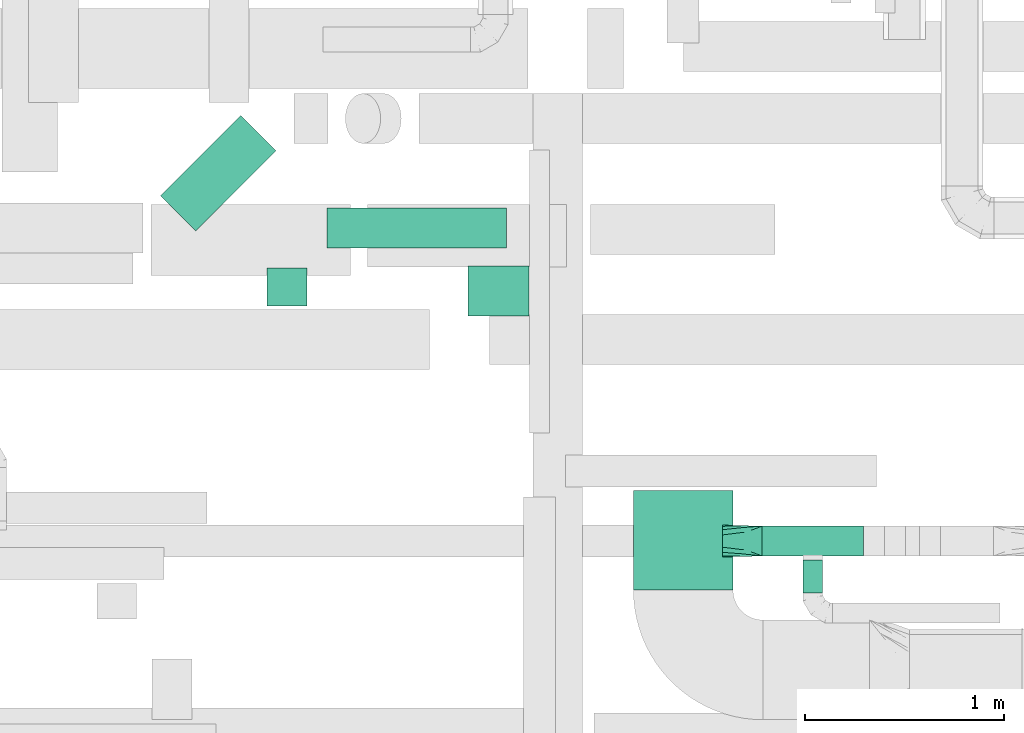
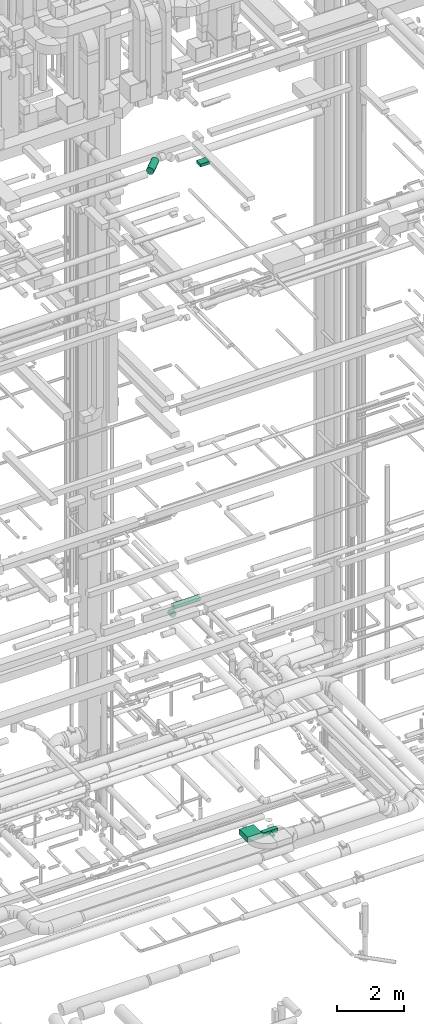
# One storey, part 209 of 337: 7 flow segments, 1 flow fitting.
"""IFC2X3 building model written with IfcOpenShell, lengths in millimetres."""

import ifcopenshell
import ifcopenshell.guid

model = None  # the IFC model being written
_history = None  # IfcOwnerHistory: only IFC2X3 demands one
_inside = {}  # id of a spatial element -> (the spatial element, [elements in it])
_under = {}  # id of a project, library or spatial element -> (it, [spatial elements below it])
_declared = {}  # id of a project -> (the project, [libraries it declares])
_typed = {}  # id of a type object -> (the type object, [elements of that type])
_made_of = {}  # id of a material, layer set ... -> (it, [elements and type objects made of it])


def new_model(schema):
    """Start an empty IFC model of exactly this schema.

    Asked for "IFC4X3", IfcOpenShell would pick the latest addendum, in which some entities
    have other attributes; the version numbers below select the first issue.
    IFC2X3 requires an IfcOwnerHistory on every rooted entity: one is made here for all.
    """
    global model, _history
    if schema == "IFC4X3":
        model = ifcopenshell.file(schema_version=(4, 3, 0, 0))
    else:
        model = ifcopenshell.file(schema=schema)
    _inside.clear()
    _under.clear()
    _declared.clear()
    _typed.clear()
    _made_of.clear()
    _history = None
    if model.schema == "IFC2X3":
        org = make("IfcOrganization", Name="unknown")
        user = make(
            "IfcPersonAndOrganization",
            ThePerson=make("IfcPerson", FamilyName="unknown"),
            TheOrganization=org,
        )
        app = make(
            "IfcApplication",
            ApplicationDeveloper=org,
            Version="unknown",
            ApplicationFullName="unknown",
            ApplicationIdentifier="unknown",
        )
        _history = make(
            "IfcOwnerHistory",
            OwningUser=user,
            OwningApplication=app,
            ChangeAction="ADDED",
            CreationDate=0,
        )
    return model


def make(cls, **values):
    """One entity of the class cls with the attributes given. An attribute that is None is left unset."""
    return model.create_entity(
        cls, **{name: value for name, value in values.items() if value is not None}
    )


def entity(cls, *values):
    """Any entity or typed value of the class cls, its attributes in the order of the schema. None: left unset."""
    e = model.create_entity(cls)
    for i, value in enumerate(values):
        if value is not None:
            e[i] = value
    return e


def rooted(cls, **values):
    """An entity with a GlobalId (a new one), such as an element, a storey or a relation."""
    return make(cls, GlobalId=ifcopenshell.guid.new(), OwnerHistory=_history, **values)


def si_unit(unit_type, name, prefix=None):
    """IfcSIUnit, for example si_unit("LENGTHUNIT", "METRE", prefix="MILLI")."""
    return make("IfcSIUnit", UnitType=unit_type, Prefix=prefix, Name=name)


def converted_unit(unit_type, name, factor, base, dimensions=None, offset=None):
    """IfcConversionBasedUnit, such as the inch: factor (a typed value) times the base unit."""
    return make(
        "IfcConversionBasedUnit"
        if offset is None
        else "IfcConversionBasedUnitWithOffset",
        ConversionOffset=offset,
        Dimensions=None
        if dimensions is None
        else entity("IfcDimensionalExponents", *dimensions),
        UnitType=unit_type,
        Name=name,
        ConversionFactor=make(
            "IfcMeasureWithUnit", ValueComponent=factor, UnitComponent=base
        ),
    )


def derived_unit(unit_type, elements):
    """IfcDerivedUnit: a product of units, each with its exponent."""
    return make(
        "IfcDerivedUnit",
        Elements=[
            make("IfcDerivedUnitElement", Unit=unit, Exponent=power)
            for unit, power in elements
        ],
        UnitType=unit_type,
    )


def assignment(units):
    """IfcUnitAssignment: the units of a project."""
    return None if units is None else make("IfcUnitAssignment", Units=units)


def point(xyz):
    """IfcCartesianPoint."""
    return None if xyz is None else make("IfcCartesianPoint", Coordinates=xyz)


def direction(xyz):
    """IfcDirection."""
    return None if xyz is None else make("IfcDirection", DirectionRatios=xyz)


def frame(location, z_axis=None, x_axis=None):
    """IfcAxis2Placement3D, a coordinate frame: its origin and axes. An axis left out is left unset."""
    return make(
        "IfcAxis2Placement3D",
        Location=point(location),
        Axis=direction(z_axis),
        RefDirection=direction(x_axis),
    )


def frame_2d(location, x_axis=None):
    """IfcAxis2Placement2D, a coordinate frame in the plane: its origin and x axis."""
    return make(
        "IfcAxis2Placement2D", Location=point(location), RefDirection=direction(x_axis)
    )


def origin():
    """The frame at (0, 0, 0) with its axes left unset."""
    return frame((0.0, 0.0, 0.0))


def origin_2d_with_axis():
    """The frame at (0, 0) in the plane with the x axis (1, 0) written out."""
    return frame_2d((0.0, 0.0), x_axis=(1.0, 0.0))


def place(relative_to, where):
    """IfcLocalPlacement: puts the frame where relative to a parent placement (None: the world)."""
    return make(
        "IfcLocalPlacement", PlacementRelTo=relative_to, RelativePlacement=where
    )


def context(
    kind, dimensions, precision=None, world=None, true_north=None, identifier=None
):
    """IfcGeometricRepresentationContext, for example the 3D "Model" context."""
    return make(
        "IfcGeometricRepresentationContext",
        ContextIdentifier=identifier,
        ContextType=kind,
        CoordinateSpaceDimension=dimensions,
        Precision=precision,
        WorldCoordinateSystem=world,
        TrueNorth=true_north,
    )


def subcontext(parent, identifier, kind, view, scale=None):
    """IfcGeometricRepresentationSubContext, for example "Body" below "Model"."""
    return make(
        "IfcGeometricRepresentationSubContext",
        ContextIdentifier=identifier,
        ContextType=kind,
        ParentContext=parent,
        TargetScale=scale,
        TargetView=view,
    )


def project(units=None, contexts=None):
    """IfcProject with its units and contexts."""
    return rooted(
        "IfcProject",
        Name="project",
        RepresentationContexts=contexts,
        UnitsInContext=assignment(units),
    )


def spatial(cls, under=None, at=None, **own):
    """A site, building, storey or space (cls), placed at a placement, below another one or the project."""
    s = rooted(cls, ObjectPlacement=at, **own)
    if under is not None:
        _under.setdefault(under.id(), (under, []))[1].append(s)
    return s


def profile(cls, at=None, kind="AREA", **sizes):
    """A parametric profile (cls). Its sizes go by their IFC names, for example OverallWidth=200.0."""
    return make(cls, ProfileType=kind, Position=at, **sizes)


def rectangle(**sizes):
    """IfcRectangleProfileDef."""
    return profile("IfcRectangleProfileDef", **sizes)


def circle(**sizes):
    """IfcCircleProfileDef."""
    return profile("IfcCircleProfileDef", **sizes)


def extrude(swept, where, along, depth):
    """IfcExtrudedAreaSolid: the profile swept, set in the frame where, extruded along a direction by depth."""
    return make(
        "IfcExtrudedAreaSolid",
        SweptArea=swept,
        Position=where,
        ExtrudedDirection=direction(along),
        Depth=depth,
    )


def faces_of(points, faces, orient=None, outer=None):
    """IfcFace entities. A face is a list of loops; a loop is a list of indices into points, from 0.

    orient and outer hold one flag for each loop. By default every Orientation is true, the
    first loop of a face is its IfcFaceOuterBound and the others are IfcFaceBound.
    """
    made = []
    for i, loops in enumerate(faces):
        bounds = []
        for j, loop in enumerate(loops):
            is_outer = j == 0 if outer is None else outer[i][j]
            bounds.append(
                make(
                    "IfcFaceOuterBound" if is_outer else "IfcFaceBound",
                    Bound=make("IfcPolyLoop", Polygon=[points[k] for k in loop]),
                    Orientation=True if orient is None else orient[i][j],
                )
            )
        made.append(make("IfcFace", Bounds=bounds))
    return made


def faceted_brep(points, faces, orient=None, outer=None, voids=None):
    """IfcFacetedBrep: a solid bounded by flat faces; with voids (closed shells), ...WithVoids."""
    shared = [point(p) for p in points]
    hull = make("IfcClosedShell", CfsFaces=faces_of(shared, faces, orient, outer))
    if voids is None:
        return make("IfcFacetedBrep", Outer=hull)
    return make(
        "IfcFacetedBrepWithVoids",
        Outer=hull,
        Voids=[
            make(cls, CfsFaces=faces_of(shared, fs, o, b)) for cls, fs, o, b in voids
        ],
    )


def shape(context_of_items, identifier, shape_type, items):
    """IfcShapeRepresentation: the items that make up one representation, for example the "Body"."""
    return make(
        "IfcShapeRepresentation",
        ContextOfItems=context_of_items,
        RepresentationIdentifier=identifier,
        RepresentationType=shape_type,
        Items=items,
    )


def source(mapping_origin, context_of_items, identifier, shape_type, items):
    """IfcRepresentationMap: a shape defined once, which mapped items show again and again."""
    return make(
        "IfcRepresentationMap",
        MappingOrigin=mapping_origin,
        MappedRepresentation=shape(context_of_items, identifier, shape_type, items),
    )


def transform(
    local_origin,
    x_axis=None,
    y_axis=None,
    z_axis=None,
    scale=None,
    scale2=None,
    scale3=None,
    uniform=True,
):
    """IfcCartesianTransformationOperator3D, or its non-uniform kind. x_axis, y_axis, z_axis: its Axis1, 2, 3."""
    if uniform:
        return make(
            "IfcCartesianTransformationOperator3D",
            Axis1=direction(x_axis),
            Axis2=direction(y_axis),
            LocalOrigin=point(local_origin),
            Scale=scale,
            Axis3=direction(z_axis),
        )
    return make(
        "IfcCartesianTransformationOperator3DnonUniform",
        Axis1=direction(x_axis),
        Axis2=direction(y_axis),
        LocalOrigin=point(local_origin),
        Scale=scale,
        Axis3=direction(z_axis),
        Scale2=scale2,
        Scale3=scale3,
    )


def mapped(mapping_source, mapping_target):
    """IfcMappedItem: shows the shape of a source again, moved by a transform."""
    return make(
        "IfcMappedItem", MappingSource=mapping_source, MappingTarget=mapping_target
    )


def material(Name=None, Category=None):
    """IfcMaterial."""
    return make("IfcMaterial", Name=Name, Category=Category)


def made_of(thing, what):
    """Note that an element or type object is made of a material, layer set ...; save() writes the relation."""
    if what is not None:
        _made_of.setdefault(what.id(), (what, []))[1].append(thing)
    return thing


def type_object(cls, material=None, **own):
    """A type object (cls), such as IfcWallType, which elements share."""
    return made_of(rooted(cls, **own), material)


def type_shapes(of_type, sources):
    """Give a type object the sources (RepresentationMaps) that its elements show as mapped items."""
    of_type.RepresentationMaps = sources


def element(
    cls,
    number,
    at=None,
    inside=None,
    cuts=None,
    type_object=None,
    material=None,
    context=None,
    identifier="Body",
    shape_type=None,
    held_by="IfcProductDefinitionShape",
    body=None,
    shapes=None,
    **own,
):
    """One element of the class cls, such as IfcWall. Its Tag is "e" and its number.

    at: its placement. inside: the storey or other place that contains it. cuts: it is an
    opening in that element (IfcRelVoidsElement). A single representation is given by context,
    identifier, shape_type and body (its items); several are given by shapes. held_by: the class
    of the entity that holds the representations. save() writes the other relations.
    """
    e = rooted(cls, Tag="e%d" % number, ObjectPlacement=at, **own)
    if body is not None:
        shapes = [shape(context, identifier, shape_type, body)]
    if shapes is not None:
        e.Representation = make(held_by, Representations=shapes)
    if inside is not None:
        _inside.setdefault(inside.id(), (inside, []))[1].append(e)
    if cuts is not None:
        rooted(
            "IfcRelVoidsElement", RelatingBuildingElement=cuts, RelatedOpeningElement=e
        )
    if type_object is not None:
        _typed.setdefault(type_object.id(), (type_object, []))[1].append(e)
    return made_of(e, material)


def aggregate(whole, parts):
    """IfcRelAggregates: a whole, such as a stair, and the parts it consists of."""
    return rooted("IfcRelAggregates", RelatingObject=whole, RelatedObjects=parts)


def save(model, path):
    """Write the relations noted so far, then the file.

    IfcRelAggregates (storeys below a building ...), IfcRelContainedInSpatialStructure (elements
    in a storey), IfcRelDefinesByType, IfcRelAssociatesMaterial and IfcRelDeclares: one each for
    every whole, place, type object, material and project.
    """
    for whole, parts in _under.values():
        aggregate(whole, parts)
    for where, things in _inside.values():
        rooted(
            "IfcRelContainedInSpatialStructure",
            RelatedElements=things,
            RelatingStructure=where,
        )
    for kind, things in _typed.values():
        rooted("IfcRelDefinesByType", RelatedObjects=things, RelatingType=kind)
    for what, things in _made_of.values():
        rooted("IfcRelAssociatesMaterial", RelatedObjects=things, RelatingMaterial=what)
    for by, libraries in _declared.values():
        rooted("IfcRelDeclares", RelatingContext=by, RelatedDefinitions=libraries)
    model.write(path)


model = new_model("IFC2X3")

# Units and contexts
model_context = context("Model", 3, precision=0.01, world=origin(), true_north=direction((6.12303176911189e-17, 1.0)))
body_context = subcontext(model_context, "Body", "Model", "MODEL_VIEW")
ifc_project = project(units=[si_unit("LENGTHUNIT", "METRE", prefix="MILLI"), si_unit("AREAUNIT", "SQUARE_METRE"), si_unit("VOLUMEUNIT", "CUBIC_METRE"), converted_unit("PLANEANGLEUNIT", "DEGREE", entity("IfcRatioMeasure", 0.0174532925199433), si_unit("PLANEANGLEUNIT", "RADIAN"), dimensions=[0, 0, 0, 0, 0, 0, 0]), si_unit("MASSUNIT", "GRAM", prefix="KILO"), derived_unit("MASSDENSITYUNIT", [(si_unit("MASSUNIT", "GRAM", prefix="KILO"), 1), (si_unit("LENGTHUNIT", "METRE"), -3)]), derived_unit("MOMENTOFINERTIAUNIT", [(si_unit("LENGTHUNIT", "METRE"), 4)]), si_unit("TIMEUNIT", "SECOND"), si_unit("FREQUENCYUNIT", "HERTZ"), si_unit("THERMODYNAMICTEMPERATUREUNIT", "DEGREE_CELSIUS"), derived_unit("THERMALTRANSMITTANCEUNIT", [(si_unit("MASSUNIT", "GRAM", prefix="KILO"), 1), (si_unit("THERMODYNAMICTEMPERATUREUNIT", "KELVIN"), -1), (si_unit("TIMEUNIT", "SECOND"), -3)]), derived_unit("VOLUMETRICFLOWRATEUNIT", [(si_unit("LENGTHUNIT", "METRE"), 3), (si_unit("TIMEUNIT", "SECOND"), -1)]), derived_unit("MASSFLOWRATEUNIT", [(si_unit("MASSUNIT", "GRAM", prefix="KILO"), 1), (si_unit("TIMEUNIT", "SECOND"), -1)]), derived_unit("ROTATIONALFREQUENCYUNIT", [(si_unit("TIMEUNIT", "SECOND"), -1)]), si_unit("ELECTRICCURRENTUNIT", "AMPERE"), si_unit("ELECTRICVOLTAGEUNIT", "VOLT"), si_unit("POWERUNIT", "WATT"), si_unit("FORCEUNIT", "NEWTON", prefix="KILO"), si_unit("ILLUMINANCEUNIT", "LUX"), si_unit("LUMINOUSFLUXUNIT", "LUMEN"), si_unit("LUMINOUSINTENSITYUNIT", "CANDELA"), derived_unit("USERDEFINED", [(si_unit("MASSUNIT", "GRAM", prefix="KILO"), -1), (si_unit("LENGTHUNIT", "METRE"), -2), (si_unit("TIMEUNIT", "SECOND"), 3), (si_unit("LUMINOUSFLUXUNIT", "LUMEN"), 1)]), derived_unit("LINEARVELOCITYUNIT", [(si_unit("LENGTHUNIT", "METRE"), 1), (si_unit("TIMEUNIT", "SECOND"), -1)]), si_unit("PRESSUREUNIT", "PASCAL"), derived_unit("USERDEFINED", [(si_unit("LENGTHUNIT", "METRE"), -2), (si_unit("MASSUNIT", "GRAM", prefix="KILO"), 1), (si_unit("TIMEUNIT", "SECOND"), -2)]), derived_unit("LINEARFORCEUNIT", [(si_unit("MASSUNIT", "GRAM", prefix="KILO"), 1), (si_unit("LENGTHUNIT", "METRE"), 1), (si_unit("TIMEUNIT", "SECOND"), -2), (si_unit("LENGTHUNIT", "METRE"), -1)]), derived_unit("PLANARFORCEUNIT", [(si_unit("MASSUNIT", "GRAM", prefix="KILO"), 1), (si_unit("LENGTHUNIT", "METRE"), 1), (si_unit("TIMEUNIT", "SECOND"), -2), (si_unit("LENGTHUNIT", "METRE"), -2)])], contexts=[model_context])

# Site, building, storey
site_placement = place(None, origin())
site = spatial("IfcSite", under=ifc_project, at=site_placement, CompositionType="ELEMENT")
building_placement = place(site_placement, origin())
building = spatial("IfcBuilding", under=site, at=building_placement, CompositionType="ELEMENT")
storey_placement = place(building_placement, origin())
storey = spatial("IfcBuildingStorey", under=building, at=storey_placement, CompositionType="ELEMENT", Elevation=0.0)

# Flow segments
duct_segment_type_1 = type_object("IfcDuctSegmentType", PredefinedType="NOTDEFINED")
flow_segment_1_placement = place(storey_placement, frame((59249.3, 5238.77, 27500.0)))
element("IfcFlowSegment", 1, at=flow_segment_1_placement, inside=storey, type_object=duct_segment_type_1, context=body_context, shape_type="SweptSolid", body=[
    extrude(rectangle(XDim=305.269119345866, YDim=249.999999999999, at=origin_2d_with_axis()), frame((152.63, 125.0, 0.0), z_axis=(0.0, 0.0, 1.0), x_axis=(-1.0, 0.0, 0.0)), (0.0, 0.0, 1.0), 100.000000000003),
])
flow_segment_2_placement = place(storey_placement, frame((60078.78, 3864.15, 3300.0)))
element("IfcFlowSegment", 2, at=flow_segment_2_placement, inside=storey, type_object=duct_segment_type_1, context=body_context, shape_type="SweptSolid", body=[
    extrude(rectangle(XDim=500.000000000007, YDim=499.999999999999, at=origin_2d_with_axis()), frame((250.0, 250.0, 0.0), z_axis=(0.0, 0.0, 1.0), x_axis=(0.0, 1.0, 0.0)), (0.0, 0.0, 1.0), 200.0),
])
flow_segment_3_placement = place(storey_placement, frame((60725.0, 4035.29, 3175.0)))
element("IfcFlowSegment", 3, at=flow_segment_3_placement, inside=storey, type_object=duct_segment_type_1, context=body_context, shape_type="SweptSolid", body=[
    extrude(rectangle(XDim=507.883896932124, YDim=150.0, at=origin_2d_with_axis()), frame((253.94, 75.0, 0.0), z_axis=(0.0, 0.0, 1.0), x_axis=(-1.0, 0.0, 0.0)), (0.0, 0.0, 1.0), 150.000000000001),
])
duct_segment_type_2 = type_object("IfcDuctSegmentType", PredefinedType="NOTDEFINED")
flow_segment_4_placement = place(storey_placement, frame((58240.01, 5290.54, 11298.4)))
element("IfcFlowSegment", 4, at=flow_segment_4_placement, inside=storey, type_object=duct_segment_type_2, context=body_context, shape_type="SweptSolid", body=[
    extrude(circle(Radius=100.0, at=origin_2d_with_axis()), frame((101.6, 0.0, 101.6), z_axis=(0.0, 1.0, 0.0), x_axis=(-1.0, 0.0, 0.0)), (0.0, 0.0, 1.0), 190.000000000098),
])
flow_segment_5_placement = place(storey_placement, frame((58541.61, 5578.95, 11298.4)))
element("IfcFlowSegment", 5, at=flow_segment_5_placement, inside=storey, type_object=duct_segment_type_2, context=body_context, shape_type="SweptSolid", body=[
    extrude(circle(Radius=100.0, at=origin_2d_with_axis()), frame((0.0, 101.6, 101.6), z_axis=(1.0, 0.0, 0.0), x_axis=(0.0, -1.0, 0.0)), (0.0, 0.0, 1.0), 899.999999999969),
])
flow_segment_6_placement = place(storey_placement, frame((57705.63, 5663.52, 27423.4)))
element("IfcFlowSegment", 6, at=flow_segment_6_placement, inside=storey, type_object=duct_segment_type_2, context=body_context, shape_type="SweptSolid", body=[
    extrude(circle(Radius=125.0, at=origin_2d_with_axis()), frame((89.98, 89.98, 126.6), z_axis=(0.707106781186518, 0.707106781186577, 0.0), x_axis=(0.707106781186577, -0.707106781186518, 0.0)), (0.0, 0.0, 1.0), 570.112127880552),
])
flow_segment_7_placement = place(storey_placement, frame((60927.15, 3850.29, 3198.4)))
element("IfcFlowSegment", 7, at=flow_segment_7_placement, inside=storey, type_object=duct_segment_type_2, context=body_context, shape_type="SweptSolid", body=[
    extrude(circle(Radius=50.0, at=origin_2d_with_axis()), frame((51.6, 0.0, 51.6), z_axis=(0.0, 1.0, 0.0), x_axis=(1.0, 0.0, 0.0)), (0.0, 0.0, 1.0), 164.999999999989),
])

# Flow fitting
ifc_material = material()
duct_fitting_type = type_object("IfcDuctFittingType", PredefinedType="NOTDEFINED", material=ifc_material)
shared_shape = source(origin(), body_context, "Body", "Brep", [
    faceted_brep([(200.0, 30.61, 73.91), (200.0, 22.87, 75.45), (200.0, 15.12, 76.99), (200.0, 11.34, 77.74), (200.0, 7.56, 78.5), (200.0, 0.0, 80.0), (200.0, -7.56, 78.5), (200.0, -15.12, 76.99), (200.0, -18.99, 76.22), (200.0, -22.87, 75.45), (200.0, -30.61, 73.91), (200.0, -37.1, 69.57), (200.0, -43.59, 65.24), (200.0, -50.08, 60.9), (200.0, -56.57, 56.57), (200.0, -60.9, 50.08), (200.0, -65.24, 43.59), (200.0, -69.57, 37.1), (200.0, -73.91, 30.61), (200.0, -75.45, 22.87), (200.0, -76.99, 15.12), (200.0, -77.74, 11.34), (200.0, -78.5, 7.56), (200.0, -80.0, 0.0), (200.0, -78.5, -7.56), (200.0, -76.99, -15.12), (200.0, -76.22, -18.99), (200.0, -75.45, -22.87), (200.0, -73.91, -30.61), (200.0, -69.57, -37.1), (200.0, -65.24, -43.59), (200.0, -60.9, -50.08), (200.0, -56.57, -56.57), (200.0, -50.08, -60.9), (200.0, -43.59, -65.24), (200.0, -37.1, -69.57), (200.0, -30.61, -73.91), (200.0, -22.87, -75.45), (200.0, -15.12, -76.99), (200.0, -11.34, -77.74), (200.0, -7.56, -78.5), (200.0, 0.0, -80.0), (200.0, 7.56, -78.5), (200.0, 15.12, -76.99), (200.0, 18.99, -76.22), (200.0, 22.87, -75.45), (200.0, 30.61, -73.91), (200.0, 37.1, -69.57), (200.0, 43.59, -65.24), (200.0, 50.08, -60.9), (200.0, 56.57, -56.57), (200.0, 60.9, -50.08), (200.0, 65.24, -43.59), (200.0, 69.57, -37.1), (200.0, 73.91, -30.61), (200.0, 75.45, -22.87), (200.0, 76.99, -15.12), (200.0, 77.74, -11.34), (200.0, 78.5, -7.56), (200.0, 80.0, 0.0), (200.0, 78.5, 7.56), (200.0, 76.99, 15.12), (200.0, 76.22, 18.99), (200.0, 75.45, 22.87), (200.0, 73.91, 30.61), (200.0, 69.57, 37.1), (200.0, 65.24, 43.59), (200.0, 60.9, 50.08), (200.0, 56.57, 56.57), (200.0, 50.08, 60.9), (200.0, 43.59, 65.24), (200.0, 37.1, 69.57), (0.0, -75.0, 75.0), (0.0, 75.0, 75.0), (0.0, 75.0, -75.0), (0.0, -75.0, -75.0), (52.06, -55.48, 76.3), (78.09, -45.72, 76.95), (176.03, -8.99, 79.4), (152.06, -17.98, 78.8), (128.09, -26.97, 78.2), (104.11, -35.96, 77.6), (100.0, -67.44, 64.02), (78.09, -76.95, 45.72), (104.11, -77.6, 35.96), (128.09, -78.2, 26.97), (152.06, -78.8, 17.98), (164.04, -79.1, 13.48), (176.03, -79.4, 8.99), (26.03, -75.65, 65.24), (52.06, -76.3, 55.48), (26.03, -65.24, 75.65), (26.03, -75.65, -65.24), (52.06, -76.3, -55.48), (78.09, -76.95, -45.72), (104.11, -77.6, -35.96), (128.09, -78.2, -26.97), (152.06, -78.8, -17.98), (176.03, -79.4, -8.99), (100.0, -64.02, -67.44), (78.09, -45.72, -76.95), (104.11, -35.96, -77.6), (128.09, -26.97, -78.2), (152.06, -17.98, -78.8), (164.04, -13.48, -79.1), (176.03, -8.99, -79.4), (26.03, -65.24, -75.65), (52.06, -55.48, -76.3), (26.03, 65.24, -75.65), (52.06, 55.48, -76.3), (78.09, 45.72, -76.95), (104.11, 35.96, -77.6), (128.09, 26.97, -78.2), (152.06, 17.98, -78.8), (176.03, 8.99, -79.4), (100.0, 67.44, -64.02), (78.09, 76.95, -45.72), (104.11, 77.6, -35.96), (128.09, 78.2, -26.97), (152.06, 78.8, -17.98), (164.04, 79.1, -13.48), (176.03, 79.4, -8.99), (26.03, 75.65, -65.24), (52.06, 76.3, -55.48), (26.03, 75.65, 65.24), (52.06, 76.3, 55.48), (78.09, 76.95, 45.72), (104.11, 77.6, 35.96), (128.09, 78.2, 26.97), (152.06, 78.8, 17.98), (176.03, 79.4, 8.99), (100.0, 64.02, 67.44), (78.09, 45.72, 76.95), (104.11, 35.96, 77.6), (128.09, 26.97, 78.2), (152.06, 17.98, 78.8), (164.04, 13.48, 79.1), (176.03, 8.99, 79.4), (26.03, 65.24, 75.65), (52.06, 55.48, 76.3)], [[[0, 1, 2, 3, 4, 5, 6, 7, 8, 9, 10, 11, 12, 13, 14, 15, 16, 17, 18, 19, 20, 21, 22, 23, 24, 25, 26, 27, 28, 29, 30, 31, 32, 33, 34, 35, 36, 37, 38, 39, 40, 41, 42, 43, 44, 45, 46, 47, 48, 49, 50, 51, 52, 53, 54, 55, 56, 57, 58, 59, 60, 61, 62, 63, 64, 65, 66, 67, 68, 69, 70, 71]], [[72, 73, 74, 75]], [[76, 12, 77]], [[12, 11, 10, 77]], [[78, 79, 80, 81, 77, 10, 9, 8, 7, 6, 5]], [[13, 82, 14]], [[20, 19, 18, 83, 84, 85, 86, 87, 88, 23, 22, 21]], [[82, 72, 89]], [[82, 15, 14]], [[83, 16, 90]], [[91, 72, 82]], [[18, 17, 16, 83]], [[90, 16, 15]], [[15, 82, 89]], [[90, 15, 89]], [[76, 13, 12]], [[13, 76, 91]], [[82, 13, 91]], [[88, 87, 86, 85, 84, 83, 90, 89, 72, 75, 92, 93, 94, 95, 96, 97, 98, 23]], [[93, 30, 94]], [[30, 29, 28, 94]], [[98, 97, 96, 95, 94, 28, 27, 26, 25, 24, 23]], [[31, 99, 32]], [[38, 37, 36, 100, 101, 102, 103, 104, 105, 41, 40, 39]], [[99, 75, 106]], [[99, 33, 32]], [[100, 34, 107]], [[92, 75, 99]], [[36, 35, 34, 100]], [[107, 34, 33]], [[33, 99, 106]], [[107, 33, 106]], [[93, 31, 30]], [[31, 93, 92]], [[99, 31, 92]], [[105, 104, 103, 102, 101, 100, 107, 106, 75, 74, 108, 109, 110, 111, 112, 113, 114, 41]], [[109, 48, 110]], [[48, 47, 46, 110]], [[114, 113, 112, 111, 110, 46, 45, 44, 43, 42, 41]], [[49, 115, 50]], [[56, 55, 54, 116, 117, 118, 119, 120, 121, 59, 58, 57]], [[115, 74, 122]], [[115, 51, 50]], [[116, 52, 123]], [[108, 74, 115]], [[54, 53, 52, 116]], [[123, 52, 51]], [[51, 115, 122]], [[123, 51, 122]], [[109, 49, 48]], [[49, 109, 108]], [[115, 49, 108]], [[74, 73, 124, 125, 126, 127, 128, 129, 130, 59, 121, 120, 119, 118, 117, 116, 123, 122]], [[125, 66, 126]], [[66, 65, 64, 126]], [[130, 129, 128, 127, 126, 64, 63, 62, 61, 60, 59]], [[67, 131, 68]], [[2, 1, 0, 132, 133, 134, 135, 136, 137, 5, 4, 3]], [[131, 73, 138]], [[131, 69, 68]], [[132, 70, 139]], [[124, 73, 131]], [[0, 71, 70, 132]], [[139, 70, 69]], [[69, 131, 138]], [[139, 69, 138]], [[125, 67, 66]], [[67, 125, 124]], [[131, 67, 124]], [[73, 72, 91, 76, 77, 81, 80, 79, 78, 5, 137, 136, 135, 134, 133, 132, 139, 138]]]),
])
type_shapes(duct_fitting_type, [shared_shape])
flow_fitting_placement = place(storey_placement, frame((60725.0, 4110.29, 3250.0), z_axis=(0.0, 0.0, 1.0), x_axis=(-1.0, 0.0, 0.0)))
element("IfcFlowFitting", 8, at=flow_fitting_placement, inside=storey, type_object=duct_fitting_type, material=ifc_material, context=body_context, shape_type="MappedRepresentation", body=[
    mapped(shared_shape, transform((0.0, 0.0, 0.0), scale=1.0)),
])

save(model, "model.ifc")
